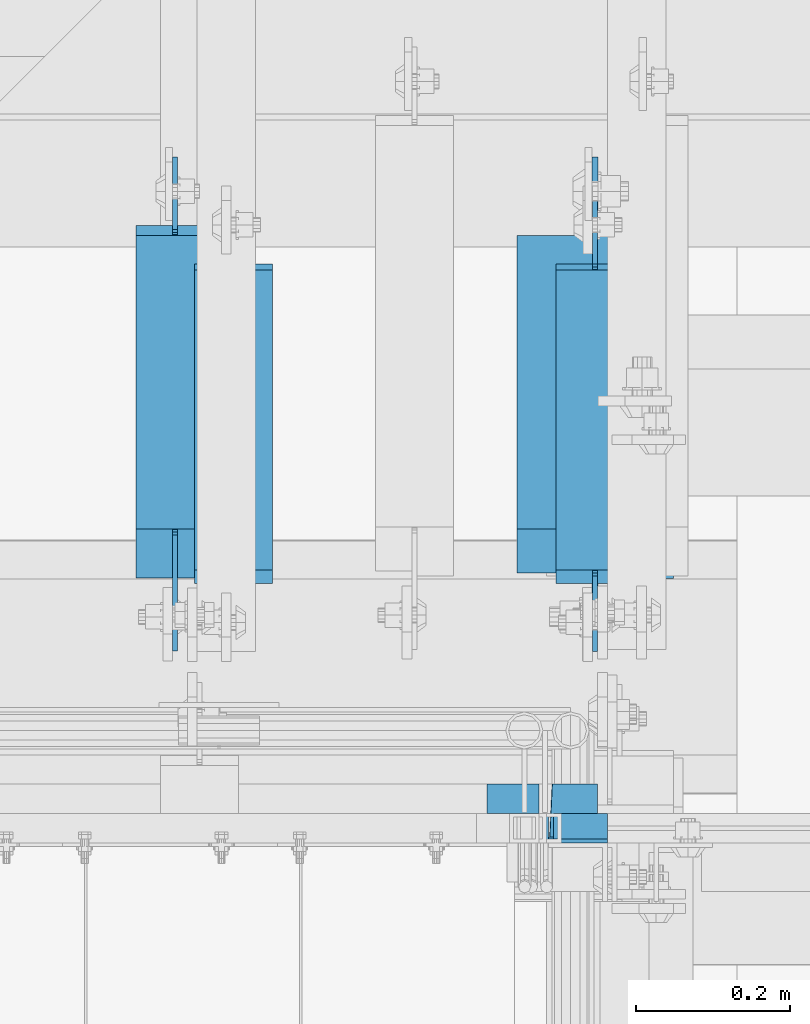
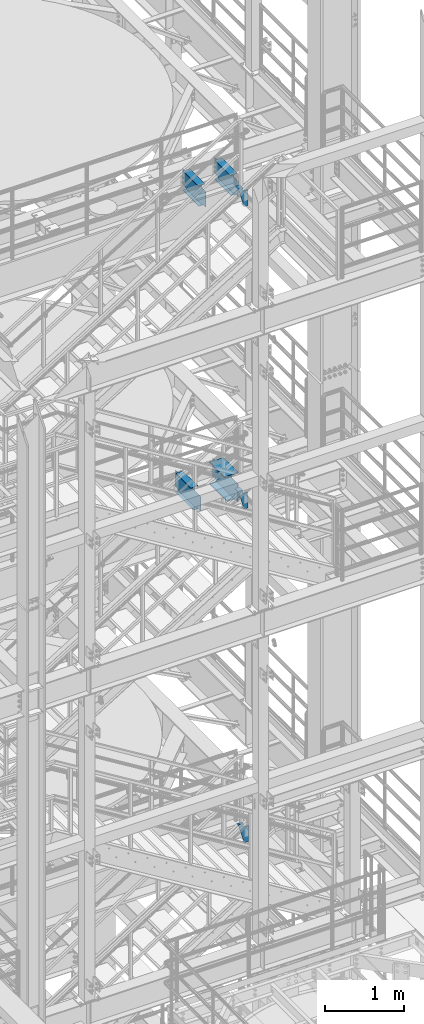
# One storey, part 1207 of 1876: 7 beams, 7 elements without a shape of their own.
"""IFC2X3 building model written with IfcOpenShell, lengths in millimetres."""

from ifc_helpers import new_model, si_unit, frame, origin_with_axes, place, context, subcontext, project, spatial, faceted_brep, material, type_object, element, aggregate, save


model = new_model("IFC2X3")

# Units and contexts
model_context = context("Model", 3, precision=1e-05, world=origin_with_axes())
body_context = subcontext(model_context, "Body", "Model", "MODEL_VIEW")
ifc_project = project(units=[si_unit("LENGTHUNIT", "METRE", prefix="MILLI"), si_unit("AREAUNIT", "SQUARE_METRE"), si_unit("VOLUMEUNIT", "CUBIC_METRE"), si_unit("MASSUNIT", "GRAM", prefix="KILO"), si_unit("TIMEUNIT", "SECOND"), si_unit("PLANEANGLEUNIT", "RADIAN"), si_unit("SOLIDANGLEUNIT", "STERADIAN"), si_unit("THERMODYNAMICTEMPERATUREUNIT", "DEGREE_CELSIUS"), si_unit("LUMINOUSINTENSITYUNIT", "LUMEN")], contexts=[model_context])

# Site, building, storey
site_placement = place(None, origin_with_axes())
site = spatial("IfcSite", under=ifc_project, at=site_placement, CompositionType="ELEMENT")
building_placement = place(site_placement, origin_with_axes())
building = spatial("IfcBuilding", under=site, at=building_placement, Name="Undefined", CompositionType="ELEMENT")
storey_placement = place(building_placement, origin_with_axes())
storey = spatial("IfcBuildingStorey", under=building, at=storey_placement, Name="Undefined", CompositionType="ELEMENT", Elevation=0.0)

# Assembly, beam
assembly_1_placement = place(storey_placement, origin_with_axes())
assembly_1 = element("IfcElementAssembly", 1, at=assembly_1_placement, inside=storey, Name="BEAM", AssemblyPlace="NOTDEFINED", PredefinedType="RIGID_FRAME")
ifc_material_1 = material(Name="STEEL/A992")
beam_type_1 = type_object("IfcBeamType", Name="W12X16", PredefinedType="NOTDEFINED")
beam_1_placement = place(assembly_1_placement, frame((6229.35, -4572.0, 17830.8), z_axis=(0.0, 0.0, 1.0), x_axis=(0.0, 1.0, 0.0)))
beam_1 = element("IfcBeam", 2, at=beam_1_placement, type_object=beam_type_1, material=ifc_material_1, Name="BEAM", ObjectType="W12X16", context=body_context, shape_type="Brep", body=[
    faceted_brep([(523.875, -3.17500000000018, -146.049999999999), (523.875, -50.8000000000002, -146.049999999999), (523.875, -50.8000000000002, -152.400000000001), (523.875, 50.8000000000002, -152.400000000001), (523.875, 50.8000000000002, -146.049999999999), (523.875, 3.17500001640747, -146.049999999999), (523.875, 3.17500003437635, -139.699999809272), (523.875, -3.17500000000018, -139.699999809272), (524.841729922588, 3.17500003361238, -134.839920291226), (524.841729922588, -3.17500000000018, -134.839920291226), (527.594743823066, 3.17500003295299, -130.719743823072), (527.594743823066, -3.17500000000018, -130.719743823072), (531.714920291219, 3.17500003250007, -127.966729922595), (531.714920291219, -3.17500000000018, -127.966729922595), (536.574999809265, 3.1750000323218, -127.000000000007), (536.574999809265, -3.17500000000018, -127.000000000007), (612.775, -3.17500000000018, -127.000000000007), (612.775, 3.17500000000018, -127.000000000007), (126.20625, 3.17499999999995, 146.049999999999), (126.20625, 50.8, 146.049999999999), (515.9375, 50.8000000000002, 146.049999999999), (515.9375, 3.17500000000018, 146.049999999999), (108.74375, -3.17499999999995, -139.699999809261), (108.74375, 3.17500002570978, -139.699999809261), (108.74375, 3.17500009516311, -146.049999999999), (108.74375, 50.8, -146.049999999999), (108.74375, 50.8, -152.400000000001), (108.74375, -50.8, -152.400000000001), (108.74375, -50.8, -146.049999999999), (108.74375, -3.17499999999995, -146.049999999999), (107.777020077412, -3.17499999999995, -134.839920291215), (107.777020077412, 3.17500002492102, -134.839920291215), (105.024006176934, -3.17499999999995, -130.719743823061), (105.024006176934, 3.17500002425209, -130.719743823061), (100.90382970878, -3.17499999999995, -127.966729922584), (100.90382970878, 3.17500002380461, -127.966729922584), (96.0437501907345, -3.17499999999995, -126.999999999996), (96.0437501907345, 3.17500002364682, -126.999999999996), (19.84375, -3.17499999999995, -126.999999999996), (19.84375, 3.17499999999995, -126.999999999996), (19.84375, -3.17499999999995, 107.950000000004), (19.84375, 3.17499999999995, 107.950000000004), (113.506250190735, -3.17499999999995, 107.950000000004), (113.506250190735, 3.17499998606149, 107.950000000004), (118.366329708781, -3.17499999999995, 108.916729922592), (118.366329708781, 3.17499998590552, 108.916729922592), (122.486506176934, -3.17499999999995, 111.669743823069), (122.486506176934, 3.17499998546009, 111.669743823069), (125.239520077413, -3.17499999999995, 115.789920291223), (125.239520077413, 3.17499998479298, 115.789920291223), (126.20625, -3.17499999999995, 120.64999980927), (126.20625, 3.17499998400558, 120.64999980927), (126.20625, -50.8, 152.400000000001), (126.20625, 50.8, 152.400000000001), (126.20625, -3.17499999999995, 146.049999999999), (126.20625, -50.8, 146.049999999999), (515.9375, -3.17500000000018, 146.049999999999), (515.9375, -50.8000000000002, 146.049999999999), (515.9375, -50.8000000000002, 152.400000000001), (515.9375, 50.8000000000002, 152.400000000001), (515.9375, -3.17500000000018, 133.349999809259), (515.9375, 3.17499999236406, 133.349999809259), (516.904229922588, -3.17500000000018, 128.489920291213), (516.904229922588, 3.17499999310803, 128.489920291213), (519.657243823066, -3.17500000000018, 124.369743823059), (519.657243823066, 3.17499999372922, 124.369743823059), (523.777420291219, -3.17500000000018, 121.616729922582), (523.777420291219, 3.17499999413303, 121.616729922582), (528.637499809265, -3.17500000000018, 120.649999999994), (528.637499809265, 3.17499999425763, 120.649999999994), (612.775, -3.17500000000018, 120.649999999994), (612.775, 3.17500000000018, 120.649999999994)], [[[0, 1, 2, 3, 4, 5, 6, 7]], [[7, 6, 8, 9]], [[9, 8, 10, 11]], [[11, 10, 12, 13]], [[13, 12, 14, 15]], [[16, 15, 14, 17]], [[18, 19, 20, 21]], [[22, 23, 24, 25, 26, 27, 28, 29]], [[30, 31, 23, 22]], [[32, 33, 31, 30]], [[34, 35, 33, 32]], [[36, 37, 35, 34]], [[38, 39, 37, 36]], [[40, 41, 39, 38]], [[42, 43, 41, 40]], [[44, 45, 43, 42]], [[46, 47, 45, 44]], [[48, 49, 47, 46]], [[50, 51, 49, 48]], [[52, 53, 19, 18, 51, 50, 54, 55]], [[55, 54, 56, 57]], [[52, 55, 57, 58]], [[53, 52, 58, 59]], [[19, 53, 59, 20]], [[58, 57, 56, 60, 61, 21, 20, 59]], [[62, 63, 61, 60]], [[64, 65, 63, 62]], [[66, 67, 65, 64]], [[68, 69, 67, 66]], [[70, 71, 69, 68]], [[71, 70, 16, 17]], [[12, 10, 8, 6, 5, 24, 23, 31, 33, 35, 37, 39, 41, 43, 45, 47, 49, 51, 18, 21, 61, 63, 65, 67, 69, 71, 17, 14]], [[25, 24, 5, 4]], [[26, 25, 4, 3]], [[27, 26, 3, 2]], [[28, 27, 2, 1]], [[29, 28, 1, 0]], [[70, 68, 66, 64, 62, 60, 56, 54, 50, 48, 46, 44, 42, 40, 38, 36, 34, 32, 30, 22, 29, 0, 7, 9, 11, 13, 15, 16]]]),
])
aggregate(assembly_1, [beam_1])

assembly_2_placement = place(storey_placement, origin_with_axes())
assembly_2 = element("IfcElementAssembly", 3, at=assembly_2_placement, inside=storey, Name="BEAM", AssemblyPlace="NOTDEFINED", PredefinedType="RIGID_FRAME")
beam_2_placement = place(assembly_2_placement, frame((5759.45, -4572.0, 17830.8), z_axis=(0.0, 0.0, 1.0), x_axis=(0.0, 1.0, 0.0)))
beam_2 = element("IfcBeam", 4, at=beam_2_placement, type_object=beam_type_1, material=ifc_material_1, Name="BEAM", ObjectType="W12X16", context=body_context, shape_type="Brep", body=[
    faceted_brep([(523.875, -3.17500000000018, -146.049999999999), (523.875, -50.8000000000002, -146.049999999999), (523.875, -50.8000000000002, -152.400000000001), (523.875, 50.8000000000002, -152.400000000001), (523.875, 50.8000000000002, -146.049999999999), (523.875, 3.17500001640747, -146.049999999999), (523.875, 3.17500003437635, -139.699999809272), (523.875, -3.17500000000018, -139.699999809272), (524.841729922588, 3.17500003361238, -134.839920291226), (524.841729922588, -3.17500000000018, -134.839920291226), (527.594743823066, 3.17500003295299, -130.719743823072), (527.594743823066, -3.17500000000018, -130.719743823072), (531.714920291219, 3.17500003250007, -127.966729922595), (531.714920291219, -3.17500000000018, -127.966729922595), (536.574999809265, 3.1750000323218, -127.000000000007), (536.574999809265, -3.17500000000018, -127.000000000007), (612.775, -3.17500000000018, -127.000000000007), (612.775, 3.17500000000018, -127.000000000007), (126.20625, 3.17499999999995, 146.049999999999), (126.20625, 50.8, 146.049999999999), (515.9375, 50.8000000000002, 146.049999999999), (515.9375, 3.17500000000018, 146.049999999999), (108.74375, -3.17499999999995, -139.699999809261), (108.74375, 3.17500002570978, -139.699999809261), (108.74375, 3.17500009516311, -146.049999999999), (108.74375, 50.8, -146.049999999999), (108.74375, 50.8, -152.400000000001), (108.74375, -50.8, -152.400000000001), (108.74375, -50.8, -146.049999999999), (108.74375, -3.17499999999995, -146.049999999999), (107.777020077412, -3.17499999999995, -134.839920291215), (107.777020077412, 3.17500002492102, -134.839920291215), (105.024006176934, -3.17499999999995, -130.719743823061), (105.024006176934, 3.17500002425209, -130.719743823061), (100.90382970878, -3.17499999999995, -127.966729922584), (100.90382970878, 3.17500002380461, -127.966729922584), (96.0437501907345, -3.17499999999995, -126.999999999996), (96.0437501907345, 3.17500002364682, -126.999999999996), (19.84375, -3.17499999999995, -126.999999999996), (19.84375, 3.17499999999995, -126.999999999996), (19.84375, -3.17499999999995, 107.950000000004), (19.84375, 3.17499999999995, 107.950000000004), (113.506250190735, -3.17499999999995, 107.950000000004), (113.506250190735, 3.17499998606149, 107.950000000004), (118.366329708781, -3.17499999999995, 108.916729922592), (118.366329708781, 3.17499998590552, 108.916729922592), (122.486506176934, -3.17499999999995, 111.669743823069), (122.486506176934, 3.17499998546009, 111.669743823069), (125.239520077413, -3.17499999999995, 115.789920291223), (125.239520077413, 3.17499998479298, 115.789920291223), (126.20625, -3.17499999999995, 120.64999980927), (126.20625, 3.17499998400558, 120.64999980927), (126.20625, 50.8, 152.400000000001), (126.20625, -50.8, 152.400000000001), (515.9375, -50.8000000000002, 152.400000000001), (515.9375, 50.8000000000002, 152.400000000001), (126.20625, -50.8, 146.049999999999), (515.9375, -50.8000000000002, 146.049999999999), (126.20625, -3.17499999999995, 146.049999999999), (515.9375, -3.17500000000018, 146.049999999999), (515.9375, -3.17500000000018, 133.349999809259), (515.9375, 3.17499999236406, 133.349999809259), (516.904229922588, -3.17500000000018, 128.489920291213), (516.904229922588, 3.17499999310803, 128.489920291213), (519.657243823066, -3.17500000000018, 124.369743823059), (519.657243823066, 3.17499999372922, 124.369743823059), (523.777420291219, -3.17500000000018, 121.616729922582), (523.777420291219, 3.17499999413303, 121.616729922582), (528.637499809265, -3.17500000000018, 120.649999999994), (528.637499809265, 3.17499999425763, 120.649999999994), (612.775, -3.17500000000018, 120.649999999994), (612.775, 3.17500000000018, 120.649999999994)], [[[0, 1, 2, 3, 4, 5, 6, 7]], [[7, 6, 8, 9]], [[9, 8, 10, 11]], [[11, 10, 12, 13]], [[13, 12, 14, 15]], [[16, 15, 14, 17]], [[18, 19, 20, 21]], [[22, 23, 24, 25, 26, 27, 28, 29]], [[30, 31, 23, 22]], [[32, 33, 31, 30]], [[34, 35, 33, 32]], [[36, 37, 35, 34]], [[38, 39, 37, 36]], [[40, 41, 39, 38]], [[42, 43, 41, 40]], [[44, 45, 43, 42]], [[46, 47, 45, 44]], [[48, 49, 47, 46]], [[50, 51, 49, 48]], [[52, 53, 54, 55]], [[53, 56, 57, 54]], [[56, 58, 59, 57]], [[53, 52, 19, 18, 51, 50, 58, 56]], [[19, 52, 55, 20]], [[54, 57, 59, 60, 61, 21, 20, 55]], [[62, 63, 61, 60]], [[64, 65, 63, 62]], [[66, 67, 65, 64]], [[68, 69, 67, 66]], [[70, 71, 69, 68]], [[71, 70, 16, 17]], [[12, 10, 8, 6, 5, 24, 23, 31, 33, 35, 37, 39, 41, 43, 45, 47, 49, 51, 18, 21, 61, 63, 65, 67, 69, 71, 17, 14]], [[25, 24, 5, 4]], [[26, 25, 4, 3]], [[27, 26, 3, 2]], [[28, 27, 2, 1]], [[29, 28, 1, 0]], [[70, 68, 66, 64, 62, 60, 59, 58, 50, 48, 46, 44, 42, 40, 38, 36, 34, 32, 30, 22, 29, 0, 7, 9, 11, 13, 15, 16]]]),
])
aggregate(assembly_2, [beam_2])

assembly_3_placement = place(storey_placement, origin_with_axes())
assembly_3 = element("IfcElementAssembly", 5, at=assembly_3_placement, inside=storey, Name="BEAM", AssemblyPlace="NOTDEFINED", PredefinedType="RIGID_FRAME")
beam_3_placement = place(assembly_3_placement, frame((5683.25, -4572.0, 13157.2), z_axis=(0.0, 0.0, 1.0), x_axis=(0.0, 1.0, 0.0)))
beam_3 = element("IfcBeam", 6, at=beam_3_placement, type_object=beam_type_1, material=ifc_material_1, Name="BEAM", ObjectType="W12X16", context=body_context, shape_type="Brep", body=[
    faceted_brep([(573.881250000001, -3.17500000000018, -146.049999999999), (573.881250000001, -50.8000000000002, -146.049999999999), (573.881250000001, -50.8000000000002, -152.4), (573.881250000001, 50.8000000000002, -152.4), (573.881250000001, 50.8000000000002, -146.049999999999), (573.881250000001, 3.17500000000018, -146.049999999999), (573.881250000001, 3.17500000000018, -139.699999809265), (573.881250000001, -3.17500000000018, -139.699999809265), (574.847979922589, 3.17500000000018, -134.839920291219), (574.847979922589, -3.17500000000018, -134.839920291219), (577.600993823067, 3.17500000000018, -130.719743823065), (577.600993823067, -3.17500000000018, -130.719743823065), (581.72117029122, 3.17500000000018, -127.966729922588), (581.72117029122, -3.17500000000018, -127.966729922588), (586.581249809266, 3.17500000000018, -127.0), (586.581249809266, -3.17500000000018, -127.0), (662.78125, -3.17500000000018, -127.0), (662.78125, 3.17500000000018, -127.0), (179.3875, 3.17500000000018, 146.049999999999), (179.3875, 50.8000000000002, 146.049999999999), (561.181250000001, 50.8000000000002, 146.049999999999), (561.181250000001, 3.17500000000018, 146.049999999999), (115.8875, -3.17500000000018, -139.699999809263), (115.8875, 3.17500000000018, -139.699999809263), (115.8875, 3.17500000000018, -146.049999999999), (115.8875, 50.8000000000002, -146.049999999999), (115.8875, 50.8000000000002, -152.4), (115.8875, -50.8000000000002, -152.4), (115.8875, -50.8000000000002, -146.049999999999), (115.8875, -3.17500000000018, -146.049999999999), (114.920770077412, -3.17500000000018, -134.839920291217), (114.920770077412, 3.17500000000018, -134.839920291217), (112.167756176934, -3.17500000000018, -130.719743823063), (112.167756176934, 3.17500000000018, -130.719743823063), (108.04757970878, -3.17500000000018, -127.966729922586), (108.04757970878, 3.17500000000018, -127.966729922586), (103.187500190735, -3.17500000000018, -126.999999999998), (103.187500190735, 3.17500000000018, -126.999999999998), (20.6374999999998, -3.17500000000018, -126.999999999998), (20.6374999999998, 3.17500000000018, -126.999999999998), (20.6374999999998, -3.17500000000018, 101.600000000002), (20.6374999999998, 3.17500000000018, 101.600000000002), (166.687500190735, -3.17500000000018, 101.600000000002), (166.687500190735, 3.17500000000018, 101.600000000002), (171.54757970878, -3.17500000000018, 102.56672992259), (171.54757970878, 3.17500000000018, 102.56672992259), (175.667756176934, -3.17500000000018, 105.319743823067), (175.667756176934, 3.17500000000018, 105.319743823067), (178.420770077412, -3.17500000000018, 109.439920291221), (178.420770077412, 3.17500000000018, 109.439920291221), (179.3875, -3.17500000000018, 114.299999809267), (179.3875, 3.17500000000018, 114.299999809267), (179.3875, -50.8000000000002, 152.4), (179.3875, 50.8000000000002, 152.4), (179.3875, -3.17500000000018, 146.049999999999), (179.3875, -50.8000000000002, 146.049999999999), (561.181250000001, -3.17500000000018, 146.049999999999), (561.181250000001, -50.8000000000002, 146.049999999999), (561.181250000001, -50.8000000000002, 152.4), (561.181250000001, 50.8000000000002, 152.4), (561.181250000001, -3.17500000000018, 133.349999809265), (561.181250000001, 3.17500000000018, 133.349999809265), (562.147979922589, -3.17500000000018, 128.489920291218), (562.147979922589, 3.17500000000018, 128.489920291218), (564.900993823067, -3.17500000000018, 124.369743823065), (564.900993823067, 3.17500000000018, 124.369743823065), (569.021170291221, -3.17500000000018, 121.616729922587), (569.021170291221, 3.17500000000018, 121.616729922587), (573.881249809266, -3.17500000000018, 120.65), (573.881249809266, 3.17500000000018, 120.65), (662.78125, -3.17500000000018, 120.65), (662.78125, 3.17500000000018, 120.65)], [[[0, 1, 2, 3, 4, 5, 6, 7]], [[7, 6, 8, 9]], [[9, 8, 10, 11]], [[11, 10, 12, 13]], [[13, 12, 14, 15]], [[16, 15, 14, 17]], [[18, 19, 20, 21]], [[22, 23, 24, 25, 26, 27, 28, 29]], [[30, 31, 23, 22]], [[32, 33, 31, 30]], [[34, 35, 33, 32]], [[36, 37, 35, 34]], [[38, 39, 37, 36]], [[40, 41, 39, 38]], [[42, 43, 41, 40]], [[44, 45, 43, 42]], [[46, 47, 45, 44]], [[48, 49, 47, 46]], [[50, 51, 49, 48]], [[52, 53, 19, 18, 51, 50, 54, 55]], [[55, 54, 56, 57]], [[52, 55, 57, 58]], [[53, 52, 58, 59]], [[19, 53, 59, 20]], [[58, 57, 56, 60, 61, 21, 20, 59]], [[62, 63, 61, 60]], [[64, 65, 63, 62]], [[66, 67, 65, 64]], [[68, 69, 67, 66]], [[70, 71, 69, 68]], [[71, 70, 16, 17]], [[12, 10, 8, 6, 5, 24, 23, 31, 33, 35, 37, 39, 41, 43, 45, 47, 49, 51, 18, 21, 61, 63, 65, 67, 69, 71, 17, 14]], [[25, 24, 5, 4]], [[26, 25, 4, 3]], [[27, 26, 3, 2]], [[28, 27, 2, 1]], [[29, 28, 1, 0]], [[70, 68, 66, 64, 62, 60, 56, 54, 50, 48, 46, 44, 42, 40, 38, 36, 34, 32, 30, 22, 29, 0, 7, 9, 11, 13, 15, 16]]]),
])
aggregate(assembly_3, [beam_3])

assembly_4_placement = place(storey_placement, origin_with_axes())
assembly_4 = element("IfcElementAssembly", 7, at=assembly_4_placement, inside=storey, Name="STRINGER", AssemblyPlace="NOTDEFINED", PredefinedType="RIGID_FRAME")
ifc_material_2 = material(Name="STEEL/A36")
beam_type_2 = type_object("IfcBeamType", Name="C12X20.7", PredefinedType="NOTDEFINED")
beam_4_placement = place(assembly_4_placement, frame((6299.19999742864, -4762.50000114118, 17865.7250011625), z_axis=(0.0, 0.0, 1.0), x_axis=(-1.0, 0.0, 0.0)))
beam_4 = element("IfcBeam", 8, at=beam_4_placement, type_object=beam_type_2, material=ifc_material_2, Name="STRINGER", ObjectType="C12X20.7", context=body_context, shape_type="Brep", body=[
    faceted_brep([(130.174997619378, 30.1625000000004, 95.25), (130.174997619378, 38.1000000000004, 95.25), (66.6749974267232, 38.1000000000004, 95.25), (66.6749974267232, 30.1625000000004, 95.25), (135.035077137423, 30.1625000000004, 96.2167299225875), (135.035077137423, 38.1000000000004, 96.2167299225875), (139.155253605577, 30.1625000000004, 98.9697438230651), (139.155253605577, 38.1000000000004, 98.9697438230651), (141.908267506055, 30.1625000000004, 103.089920291219), (141.908267506055, 38.1000000000004, 103.089920291219), (142.874997428643, 30.1625000000004, 107.949999809265), (142.874997428643, 38.1000000000004, 107.949999809265), (142.874997428643, -38.1000000000004, 152.400000000001), (142.874997428643, 38.1000000000004, 152.400000000001), (142.874997428643, 30.1625000000004, 134.6749275), (142.874997428643, -38.1000000000004, 146.047460000002), (66.6749974267232, 30.1625000000004, -134.6749275), (66.6749974267232, -38.1000000000004, -146.047460000002), (125.473451008073, -38.1000000000004, -146.047460000002), (128.710791886941, 30.1625000000004, -134.6749275), (66.6749974267232, -38.1000000000004, -152.400000000001), (123.6651169869, -38.1000000000004, -152.400000000001), (66.6749974267232, 38.1000000000004, -152.400000000001), (123.6651169869, 38.1000000000004, -152.400000000001), (210.430443872459, -38.1000000000004, 152.400000000001), (208.622109851286, -38.1000000000004, 146.047460000002), (205.384768972417, 30.1625000000004, 134.6749275), (210.430443872459, 38.1000000000004, 152.400000000001)], [[[0, 1, 2, 3]], [[4, 5, 1, 0]], [[6, 7, 5, 4]], [[8, 9, 7, 6]], [[10, 11, 9, 8]], [[12, 13, 11, 10, 14, 15]], [[16, 17, 18, 19]], [[17, 20, 21, 18]], [[20, 22, 23, 21]], [[24, 25, 26, 19, 18, 21, 23, 27]], [[25, 24, 12, 15]], [[26, 25, 15, 14]], [[8, 6, 4, 0, 3, 16, 19, 26, 14, 10]], [[22, 20, 17, 16, 3, 2]], [[27, 23, 22, 2, 1, 5, 7, 9, 11, 13]], [[24, 27, 13, 12]]]),
])
aggregate(assembly_4, [beam_4])

assembly_5_placement = place(storey_placement, origin_with_axes())
assembly_5 = element("IfcElementAssembly", 9, at=assembly_5_placement, inside=storey, Name="STRINGER", AssemblyPlace="NOTDEFINED", PredefinedType="RIGID_FRAME")
beam_5_placement = place(assembly_5_placement, frame((6299.19999999748, -4762.50000114192, 13192.1250000172), z_axis=(0.0, 0.0, 1.0), x_axis=(-1.0, 0.0, 0.0)))
beam_5 = element("IfcBeam", 10, at=beam_5_placement, type_object=beam_type_2, material=ifc_material_2, Name="STRINGER", ObjectType="C12X20.7", context=body_context, shape_type="Brep", body=[
    faceted_brep([(130.174997619378, 30.1625000000004, 95.25), (130.174997619378, 38.1000000000004, 95.25), (66.6749974267232, 38.1000000000004, 95.25), (66.6749974267232, 30.1625000000004, 95.25), (135.035077137423, 30.1625000000004, 96.2167299225875), (135.035077137423, 38.1000000000004, 96.2167299225875), (139.155253605577, 30.1625000000004, 98.9697438230651), (139.155253605577, 38.1000000000004, 98.9697438230651), (141.908267506055, 30.1625000000004, 103.089920291219), (141.908267506055, 38.1000000000004, 103.089920291219), (142.874997428643, 30.1625000000004, 107.949999809265), (142.874997428643, 38.1000000000004, 107.949999809265), (142.874997428643, -38.1000000000004, 152.400000000001), (142.874997428643, 38.1000000000004, 152.400000000001), (142.874997428643, 30.1625000000004, 134.6749275), (142.874997428643, -38.1000000000004, 146.047460000002), (66.6749974267232, 30.1625000000004, -134.6749275), (66.6749974267232, -38.1000000000004, -146.047460000002), (125.940982455932, -38.1000000000004, -146.04746), (129.158850469417, 30.1625000000004, -134.6749275), (66.6749974267232, -38.1000000000004, -152.400000000001), (124.143525709126, -38.1000000000004, -152.4), (66.6749974267232, 38.1000000000004, -152.400000000001), (124.143525709126, 38.1000000000004, -152.4), (210.386952185191, -38.1000000000004, 152.4), (208.589495438386, -38.1000000000004, 146.04746), (205.371627424901, 30.1625000000004, 134.6749275), (210.386952185191, 38.1000000000004, 152.4)], [[[0, 1, 2, 3]], [[4, 5, 1, 0]], [[6, 7, 5, 4]], [[8, 9, 7, 6]], [[10, 11, 9, 8]], [[12, 13, 11, 10, 14, 15]], [[16, 17, 18, 19]], [[17, 20, 21, 18]], [[20, 22, 23, 21]], [[24, 25, 26, 19, 18, 21, 23, 27]], [[25, 24, 12, 15]], [[26, 25, 15, 14]], [[8, 6, 4, 0, 3, 16, 19, 26, 14, 10]], [[22, 20, 17, 16, 3, 2]], [[27, 23, 22, 2, 1, 5, 7, 9, 11, 13]], [[24, 27, 13, 12]]]),
])
aggregate(assembly_5, [beam_5])

assembly_6_placement = place(storey_placement, origin_with_axes())
assembly_6 = element("IfcElementAssembly", 11, at=assembly_6_placement, inside=storey, Name="STRINGER", AssemblyPlace="NOTDEFINED", PredefinedType="RIGID_FRAME")
beam_type_3 = type_object("IfcBeamType", Name="MC12X10.6", PredefinedType="NOTDEFINED")
beam_6_placement = place(assembly_6_placement, frame((6299.19999407439, -4781.55000113598, 8035.92499863022), z_axis=(0.0, 0.0, 1.0), x_axis=(-1.0, 0.0, 0.0)))
beam_6 = element("IfcBeam", 12, at=beam_6_placement, type_object=beam_type_3, material=ifc_material_2, Name="STRINGER", ObjectType="MC12X10.6", context=body_context, shape_type="Brep", body=[
    faceted_brep([(117.474994265126, 14.2875000000004, 95.25), (117.474994265126, 19.0500000000002, 95.25), (53.9749940737756, 19.0500000000002, 95.25), (53.9749940737756, 14.2875000000004, 95.25), (122.335073783172, 14.2875000000004, 96.2167299225875), (122.335073783172, 19.0500000000002, 96.2167299225875), (126.455250251325, 14.2875000000004, 98.969743823066), (126.455250251325, 19.0500000000002, 98.969743823066), (129.208264151804, 14.2875000000004, 103.08992029122), (129.208264151804, 19.0500000000002, 103.08992029122), (130.174994074391, 14.2875000000004, 107.949999809265), (130.174994074391, 19.0500000000002, 107.949999809265), (130.174994074391, -19.0500000000002, 152.4), (130.174994074391, 19.0500000000002, 152.4), (130.174994074391, 14.2875000000004, 144.17817875), (130.174994074391, -19.0500000000002, 144.841595), (53.9749940737756, 14.2875000000004, -144.17817875), (53.9749940737756, -19.0500000000002, -144.841595), (124.039540700192, -19.0500000000002, -144.841595), (124.232727968174, 14.2875000000004, -144.17817875), (53.9749940737756, -19.0500000000002, -152.4), (121.838527969119, -19.0500000000002, -152.4), (53.9749940737756, 19.0500000000002, -152.4), (121.838527969119, 19.0500000000002, -152.4), (210.596497465463, -19.0500000000002, 152.4), (208.395484734389, -19.0500000000002, 144.841595), (208.202297466408, 14.2875000000004, 144.17817875), (210.596497465463, 19.0500000000002, 152.4)], [[[0, 1, 2, 3]], [[4, 5, 1, 0]], [[6, 7, 5, 4]], [[8, 9, 7, 6]], [[10, 11, 9, 8]], [[12, 13, 11, 10, 14, 15]], [[16, 17, 18, 19]], [[17, 20, 21, 18]], [[20, 22, 23, 21]], [[24, 25, 26, 19, 18, 21, 23, 27]], [[25, 24, 12, 15]], [[26, 25, 15, 14]], [[8, 6, 4, 0, 3, 16, 19, 26, 14, 10]], [[22, 20, 17, 16, 3, 2]], [[27, 23, 22, 2, 1, 5, 7, 9, 11, 13]], [[24, 27, 13, 12]]]),
])
aggregate(assembly_6, [beam_6])

assembly_7_placement = place(storey_placement, origin_with_axes())
assembly_7 = element("IfcElementAssembly", 13, at=assembly_7_placement, inside=storey, Name="BEAM", AssemblyPlace="NOTDEFINED", PredefinedType="RIGID_FRAME")
beam_type_4 = type_object("IfcBeamType", Name="W14X48", PredefinedType="NOTDEFINED")
beam_7_placement = place(assembly_7_placement, frame((6229.35, -4572.0, 13134.975), z_axis=(0.0, 0.0, 1.0), x_axis=(0.0, 1.0, 0.0)))
beam_7 = element("IfcBeam", 14, at=beam_7_placement, type_object=beam_type_4, material=ifc_material_1, Name="BEAM", ObjectType="W14X48", context=body_context, shape_type="Brep", body=[
    faceted_brep([(122.237499999999, 3.96875009536689, -158.75), (122.237499999999, 3.96875009536689, -174.625), (115.8875, 3.96875009536689, -174.625), (115.8875, 3.96875009536689, -161.924999809262), (115.255953271509, 3.96875, -158.75), (122.237499999999, 101.6, -158.75), (122.237499999999, 101.6, -174.625), (662.78125, 3.96875, 142.875), (662.78125, -3.96875, 142.875), (662.78125, -3.96875, -142.875), (662.78125, 3.96875, -142.875), (573.881249809266, 3.96875, 142.875), (573.881249809266, -3.96875, 142.875), (569.021170291221, 3.96875, 143.841729922588), (569.021170291221, -3.96875, 143.841729922588), (564.900993823067, 3.96875, 146.594743823065), (564.900993823067, -3.96875, 146.594743823065), (562.147979922589, 3.96875, 150.714920291219), (562.147979922589, -3.96875, 150.714920291219), (561.181250000001, 3.96875, 155.574999809265), (561.181250000001, -3.96875, 155.574999809265), (179.3875, 3.96875, 158.75), (179.3875, 101.6, 158.75), (561.181250000001, 101.6, 158.75), (561.181250000001, 3.96875, 158.75), (179.3875, -101.6, 174.625), (179.3875, -101.6, 158.75), (561.181250000001, -101.6, 158.75), (561.181250000001, -101.6, 174.625), (179.3875, 101.6, 174.625), (561.181250000001, 101.6, 174.625), (561.181250000001, -3.96875, 158.75), (179.3875, -3.96875, 158.75), (179.3875, 3.96875, 136.524999809268), (179.3875, -3.96875, 136.524999809268), (178.420770077412, 3.96875, 131.664920291221), (178.420770077412, -3.96875, 131.664920291221), (175.667756176934, 3.96875, 127.544743823068), (175.667756176934, -3.96875, 127.544743823068), (171.54757970878, 3.96875, 124.79172992259), (171.54757970878, -3.96875, 124.79172992259), (166.687500190735, 3.96875, 123.825000000003), (166.687500190735, -3.96875, 123.825000000003), (122.237499999999, 3.96875, 123.825000000003), (20.6374999999998, 3.96875, 123.825000000003), (20.6374999999998, -3.96875, 123.825000000003), (20.6374999999998, 3.96875, -149.224999999997), (20.6374999999998, -3.96875, -149.224999999997), (103.187500190735, 3.96875, -149.224999999997), (103.187500190735, -3.96875, -149.224999999997), (108.04757970878, 3.96875, -150.191729922584), (108.04757970878, -3.96875, -150.191729922584), (112.167756176934, 3.96875, -152.944743823062), (112.167756176934, -3.96875, -152.944743823062), (114.920770077412, 3.96875, -157.064920291215), (114.920770077412, -3.96875, -157.064920291215), (115.255953271509, -3.96875, -158.75), (561.181250000001, -3.96875, -158.75), (561.181250000001, -3.96875, -155.574999809265), (562.147979922589, -3.96875, -150.714920291219), (564.900993823067, -3.96875, -146.594743823065), (569.021170291221, -3.96875, -143.841729922588), (573.881249809266, -3.96875, -142.875), (115.255953271509, -101.6, -158.75), (561.181250000001, -101.6, -158.75), (115.8875, -101.6, -161.924999809262), (115.8875, -101.6, -174.625), (561.181250000001, -101.6, -174.625), (561.181250000001, 101.6, -174.625), (561.181250000001, 101.6, -158.75), (561.181250000001, 3.96875, -158.75), (561.181250000001, 3.96875, -155.574999809265), (562.147979922589, 3.96875, -150.714920291219), (564.900993823067, 3.96875, -146.594743823065), (569.021170291221, 3.96875, -143.841729922588), (573.881249809266, 3.96875, -142.875)], [[[0, 1, 2, 3, 4]], [[5, 6, 1, 0]], [[7, 8, 9, 10]], [[8, 7, 11, 12]], [[12, 11, 13, 14]], [[14, 13, 15, 16]], [[16, 15, 17, 18]], [[18, 17, 19, 20]], [[21, 22, 23, 24]], [[25, 26, 27, 28]], [[29, 25, 28, 30]], [[22, 29, 30, 23]], [[28, 27, 31, 20, 19, 24, 23, 30]], [[26, 32, 31, 27]], [[25, 29, 22, 21, 33, 34, 32, 26]], [[34, 33, 35, 36]], [[36, 35, 37, 38]], [[38, 37, 39, 40]], [[40, 39, 41, 42]], [[42, 41, 43, 44, 45]], [[45, 44, 46, 47]], [[47, 46, 48, 49]], [[49, 48, 50, 51]], [[51, 50, 52, 53]], [[53, 52, 54, 55]], [[8, 12, 14, 16, 18, 20, 31, 32, 34, 36, 38, 40, 42, 45, 47, 49, 51, 53, 55, 56, 57, 58, 59, 60, 61, 62, 9]], [[56, 63, 64, 57]], [[63, 65, 66, 67, 64]], [[57, 64, 67, 68, 69, 70, 71, 58]], [[58, 71, 72, 59]], [[59, 72, 73, 60]], [[60, 73, 74, 61]], [[61, 74, 75, 62]], [[9, 62, 75, 10]], [[74, 73, 72, 71, 70, 0, 4, 54, 52, 50, 48, 46, 44, 43, 41, 39, 37, 35, 33, 21, 24, 19, 17, 15, 13, 11, 7, 10, 75]], [[65, 63, 56, 55, 54, 4, 3]], [[66, 65, 3, 2]], [[68, 67, 66, 2, 1, 6]], [[69, 68, 6, 5]], [[70, 69, 5, 0]]]),
])
aggregate(assembly_7, [beam_7])

save(model, "model.ifc")
